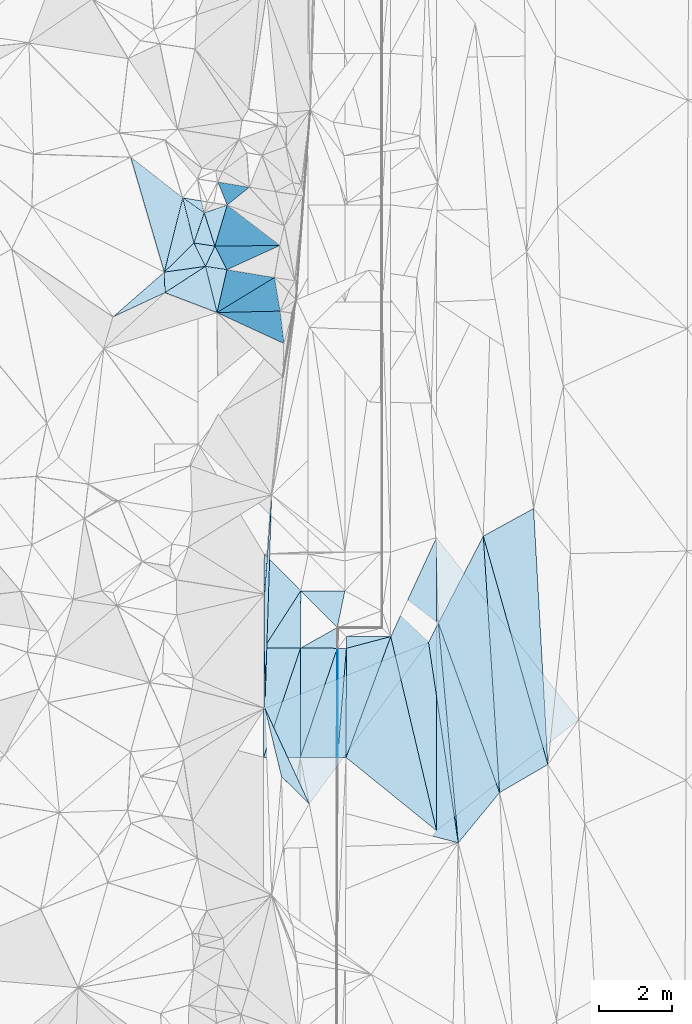
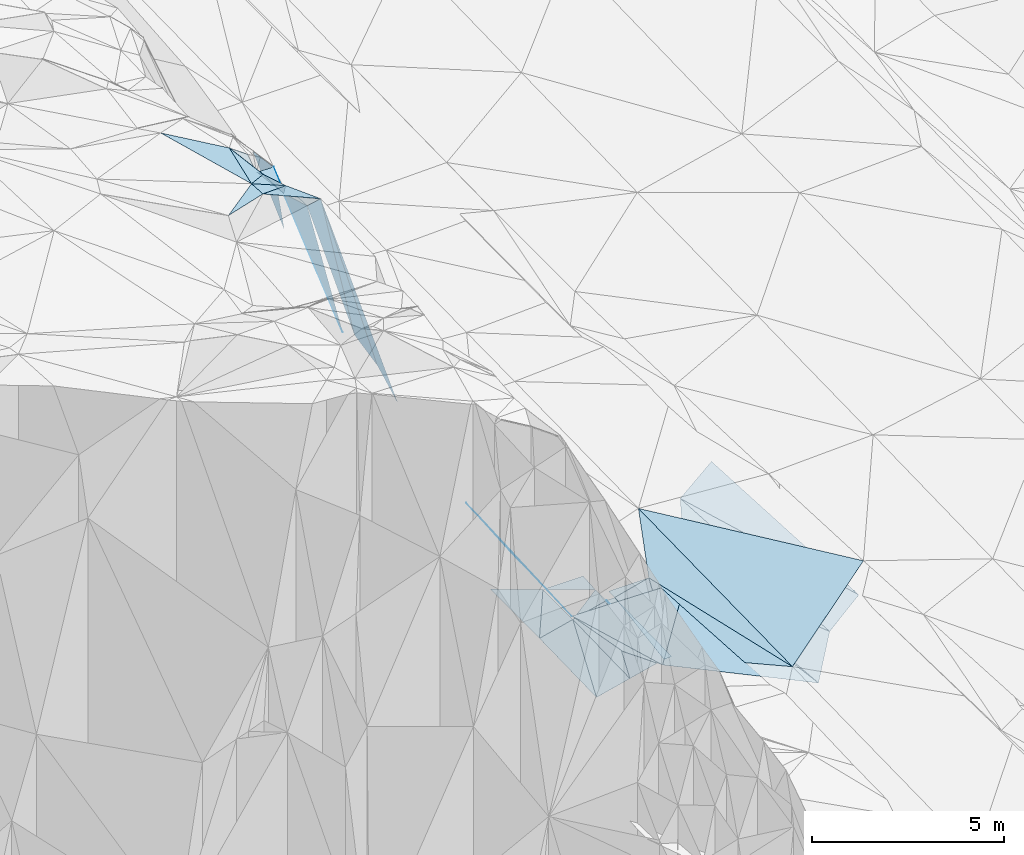
# One storey, part 128 of 275: 45 plates.
"""IFC2X3 building model written with IfcOpenShell, lengths in millimetres."""

from ifc_helpers import new_model, si_unit, frame, origin_with_axes, place, context, subcontext, project, spatial, polyline, outline, extrude, material, type_object, element, save


model = new_model("IFC2X3")

# Units and contexts
model_context = context("Model", 3, precision=1e-05, world=origin_with_axes())
body_context = subcontext(model_context, "Body", "Model", "MODEL_VIEW")
ifc_project = project(units=[si_unit("LENGTHUNIT", "METRE", prefix="MILLI"), si_unit("AREAUNIT", "SQUARE_METRE"), si_unit("VOLUMEUNIT", "CUBIC_METRE"), si_unit("MASSUNIT", "GRAM", prefix="KILO"), si_unit("TIMEUNIT", "SECOND"), si_unit("PLANEANGLEUNIT", "RADIAN"), si_unit("SOLIDANGLEUNIT", "STERADIAN"), si_unit("THERMODYNAMICTEMPERATUREUNIT", "DEGREE_CELSIUS"), si_unit("LUMINOUSINTENSITYUNIT", "LUMEN")], contexts=[model_context])

# Site, building, storey
site_placement = place(None, origin_with_axes())
site = spatial("IfcSite", under=ifc_project, at=site_placement, CompositionType="ELEMENT")
building_placement = place(site_placement, origin_with_axes())
building = spatial("IfcBuilding", under=site, at=building_placement, Name="Undefined", CompositionType="ELEMENT")
storey_placement = place(building_placement, origin_with_axes())
storey = spatial("IfcBuildingStorey", under=building, at=storey_placement, Name="Undefined", CompositionType="ELEMENT", Elevation=0.0)

# Plates
ifc_material = material()
plate_type_1 = type_object("IfcPlateType", PredefinedType="NOTDEFINED")
plate_1_placement = place(storey_placement, frame((-96862.2838496765, 102974.29921153, 42986.9687329443), z_axis=(0.049996682226141, 0.0208934366043597, -0.998530818789905), x_axis=(0.998746754522102, -0.00334002093315476, 0.0499376069884717)))
element("IfcPlate", 1, at=plate_1_placement, inside=storey, type_object=plate_type_1, material=ifc_material, Name="00_PR", context=body_context, shape_type="SweptSolid", body=[
    extrude(outline(polyline([(0.0, 0.0), (20.0249881744385, 1.60071067512035e-10), (17.6402015686035, 2980.13647460938), (0.0, 0.0)])), frame((-8.85201319254618e-08, 2.18876761149539e-07, -0.5000001331573), z_axis=(0.0, 0.0, 1.0), x_axis=(1.0, 0.0, 0.0)), (0.0, 0.0, 1.0), 1.0),
])
plate_2_placement = place(storey_placement, frame((-96851.4954782346, 99994.7710489504, 42925.1647329942), z_axis=(0.0499863724246806, 0.0208934094215203, -0.998531335519605), x_axis=(-0.998748276851681, 0.00284812192150857, -0.049937637982968)))
element("IfcPlate", 2, at=plate_2_placement, inside=storey, type_object=plate_type_1, material=ifc_material, Name="00_PR", context=body_context, shape_type="SweptSolid", body=[
    extrude(outline(polyline([(0.0, 0.0), (20.0249881744385, 1.60071067512035e-10), (16.1745891571045, 2980.14477539063), (0.0, 0.0)])), frame((-8.85201319254618e-08, 2.18876761149539e-07, -0.5000001331573), z_axis=(0.0, 0.0, 1.0), x_axis=(1.0, 0.0, 0.0)), (0.0, 0.0, 1.0), 1.0),
])
plate_type_2 = type_object("IfcPlateType", PredefinedType="NOTDEFINED")
plate_3_placement = place(storey_placement, frame((-96612.285156813, 102973.464284992, 42999.4687329028), z_axis=(0.049996682226141, 0.0208934366043597, -0.998530818789905), x_axis=(-0.0800246849124148, -0.996482893923361, -0.02485743194284)))
element("IfcPlate", 3, at=plate_3_placement, inside=storey, type_object=plate_type_2, material=ifc_material, Name="00_PR", context=body_context, shape_type="SweptSolid", body=[
    extrude(outline(polyline([(0.0, 0.0), (2989.20654296875, -5.06406649947166e-09), (17.9261016845703, 229.588638305664), (0.0, 0.0)])), frame((-8.85201319254618e-08, 2.18876761149539e-07, -0.5000001331573), z_axis=(0.0, 0.0, 1.0), x_axis=(1.0, 0.0, 0.0)), (0.0, 0.0, 1.0), 1.0),
])
plate_4_placement = place(storey_placement, frame((-96851.4954782346, 99994.7710489504, 42925.1647329942), z_axis=(0.0499863724246806, 0.0208934094215203, -0.998531335519605), x_axis=(0.0800246849207504, 0.996482893922768, 0.0248574319397589)))
element("IfcPlate", 4, at=plate_4_placement, inside=storey, type_object=plate_type_2, material=ifc_material, Name="00_PR", context=body_context, shape_type="SweptSolid", body=[
    extrude(outline(polyline([(0.0, 0.0), (2989.20654296875, -5.06406649947166e-09), (18.039421081543, 229.579437255859), (0.0, 0.0)])), frame((-8.85201319254618e-08, 2.18876761149539e-07, -0.5000001331573), z_axis=(0.0, 0.0, 1.0), x_axis=(1.0, 0.0, 0.0)), (0.0, 0.0, 1.0), 1.0),
])
plate_type_3 = type_object("IfcPlateType", PredefinedType="NOTDEFINED")
plate_5_placement = place(storey_placement, frame((-96860.382840688, 103542.363077853, 42988.3914311862), z_axis=(0.00430015277527414, -0.238494151480408, -0.971134413145652), x_axis=(-0.695041783971253, 0.697503473876836, -0.174372654002295)))
element("IfcPlate", 5, at=plate_5_placement, inside=storey, type_object=plate_type_3, material=ifc_material, Name="00_PR", context=body_context, shape_type="SweptSolid", body=[
    extrude(outline(polyline([(0.0, 0.0), (1433.71105957031, -2.65481503447518e-09), (596.104553222656, 864.556274414063), (0.0, 0.0)])), frame((-8.85201319254618e-08, 2.18876761149539e-07, -0.5000001331573), z_axis=(0.0, 0.0, 1.0), x_axis=(1.0, 0.0, 0.0)), (0.0, 0.0, 1.0), 1.0),
])
plate_type_4 = type_object("IfcPlateType", PredefinedType="NOTDEFINED")
plate_6_placement = place(storey_placement, frame((-98862.1763372869, 102980.966351325, 42486.9829273515), z_axis=(0.242537009027939, 3.20538855099889e-05, -0.970142153616845), x_axis=(0.536466447041873, 0.833191984191092, 0.134144953978825)))
element("IfcPlate", 6, at=plate_6_placement, inside=storey, type_object=plate_type_4, material=ifc_material, Name="00_PR", context=body_context, shape_type="SweptSolid", body=[
    extrude(outline(polyline([(0.0, 0.0), (1874.1591796875, 1.32422428578138e-09), (567.217834472656, 860.676391601563), (0.0, 0.0)])), frame((-8.85201319254618e-08, 2.18876761149539e-07, -0.5000001331573), z_axis=(0.0, 0.0, 1.0), x_axis=(1.0, 0.0, 0.0)), (0.0, 0.0, 1.0), 1.0),
])
plate_7_placement = place(storey_placement, frame((-97856.7525432366, 104542.50059491, 42738.3919937758), z_axis=(0.243065923693521, -0.000329820572026213, -0.970009715393308), x_axis=(-0.536466447050124, -0.833191984186519, -0.134144953974226)))
element("IfcPlate", 7, at=plate_7_placement, inside=storey, type_object=plate_type_4, material=ifc_material, Name="00_PR", context=body_context, shape_type="SweptSolid", body=[
    extrude(outline(polyline([(0.0, 0.0), (1874.1591796875, 1.32422428578138e-09), (-265.208618164063, 1408.87963867188), (0.0, 0.0)])), frame((-8.85201319254618e-08, 2.18876761149539e-07, -0.5000001331573), z_axis=(0.0, 0.0, 1.0), x_axis=(1.0, 0.0, 0.0)), (0.0, 0.0, 1.0), 1.0),
])
plate_type_5 = type_object("IfcPlateType", PredefinedType="NOTDEFINED")
plate_8_placement = place(storey_placement, frame((-96862.1875765239, 102974.289556526, 42986.9829284883), z_axis=(0.242541583059473, 0.00158451507598922, -0.970139716638268), x_axis=(-0.970137090056234, 0.00323909793626276, -0.242535636024445)))
element("IfcPlate", 8, at=plate_8_placement, inside=storey, type_object=plate_type_5, material=ifc_material, Name="00_PR", context=body_context, shape_type="SweptSolid", body=[
    extrude(outline(polyline([(0.0, 0.0), (1030.7763671875, 4.52564563602209e-09), (-0.367702662944794, 568.198425292969), (0.0, 0.0)])), frame((-8.85201319254618e-08, 2.18876761149539e-07, -0.5000001331573), z_axis=(0.0, 0.0, 1.0), x_axis=(1.0, 0.0, 0.0)), (0.0, 0.0, 1.0), 1.0),
])
plate_type_6 = type_object("IfcPlateType", PredefinedType="NOTDEFINED")
plate_9_placement = place(storey_placement, frame((-97871.3958720501, 99997.6721049398, 42674.1790293486), z_axis=(0.242551758759357, 0.0196918976460659, -0.969938592638647), x_axis=(0.00309125493136993, 0.999773210546952, 0.02107063396266)))
element("IfcPlate", 9, at=plate_9_placement, inside=storey, type_object=plate_type_6, material=ifc_material, Name="00_PR", context=body_context, shape_type="SweptSolid", body=[
    extrude(outline(polyline([(0.0, 0.0), (2980.64135742188, -1.81171344593167e-08), (2985.662109375, 1030.76416015625), (0.0, 0.0)])), frame((-8.85201319254618e-08, 2.18876761149539e-07, -0.5000001331573), z_axis=(0.0, 0.0, 1.0), x_axis=(1.0, 0.0, 0.0)), (0.0, 0.0, 1.0), 1.0),
])
plate_10_placement = place(storey_placement, frame((-98871.3913268207, 100000.516214785, 42424.1790281348), z_axis=(0.242542345699634, 0.0196919757331359, -0.969940944921001), x_axis=(0.319466040015562, 0.942410109271197, 0.099018357996012)))
element("IfcPlate", 10, at=plate_10_placement, inside=storey, type_object=plate_type_6, material=ifc_material, Name="00_PR", context=body_context, shape_type="SweptSolid", body=[
    extrude(outline(polyline([(0.0, 0.0), (3159.05053710938, -1.81462382897735e-08), (341.538848876953, 972.548278808594), (0.0, 0.0)])), frame((-8.85201319254618e-08, 2.18876761149539e-07, -0.5000001331573), z_axis=(0.0, 0.0, 1.0), x_axis=(1.0, 0.0, 0.0)), (0.0, 0.0, 1.0), 1.0),
])
plate_11_placement = place(storey_placement, frame((-97862.1819504323, 102977.637393445, 42736.9830290488), z_axis=(0.242551764417584, 0.0196885427448689, -0.969938659329806), x_axis=(-0.319466040017397, -0.942410109271267, -0.0990183579894254)))
element("IfcPlate", 11, at=plate_11_placement, inside=storey, type_object=plate_type_6, material=ifc_material, Name="00_PR", context=body_context, shape_type="SweptSolid", body=[
    extrude(outline(polyline([(0.0, 0.0), (3159.05053710938, -1.81462382897735e-08), (341.072326660156, 972.712463378906), (0.0, 0.0)])), frame((-8.85201319254618e-08, 2.18876761149539e-07, -0.5000001331573), z_axis=(0.0, 0.0, 1.0), x_axis=(1.0, 0.0, 0.0)), (0.0, 0.0, 1.0), 1.0),
])
plate_12_placement = place(storey_placement, frame((-96862.1875785642, 102974.298610799, 42986.9830277271), z_axis=(0.242542047585417, 0.0196954378779022, -0.969940949171583), x_axis=(-0.00309096492302915, -0.999773137821508, -0.021074126942329)))
element("IfcPlate", 12, at=plate_12_placement, inside=storey, type_object=plate_type_6, material=ifc_material, Name="00_PR", context=body_context, shape_type="SweptSolid", body=[
    extrude(outline(polyline([(0.0, 0.0), (2980.14721679688, 1.49739207699895e-08), (2985.66259765625, 1030.76245117188), (0.0, 0.0)])), frame((-8.85201319254618e-08, 2.18876761149539e-07, -0.5000001331573), z_axis=(0.0, 0.0, 1.0), x_axis=(1.0, 0.0, 0.0)), (0.0, 0.0, 1.0), 1.0),
])
plate_type_7 = type_object("IfcPlateType", PredefinedType="NOTDEFINED")
plate_13_placement = place(storey_placement, frame((-95402.7128464523, 103292.407908306, 43006.2141543877), z_axis=(0.021242042744292, 0.0132306099544052, -0.999686814247484), x_axis=(0.229951902921962, -0.97316916652181, -0.00799347695399914)))
element("IfcPlate", 13, at=plate_13_placement, inside=storey, type_object=plate_type_7, material=ifc_material, Name="00_PR", context=body_context, shape_type="SweptSolid", body=[
    extrude(outline(polyline([(0.0, 0.0), (5443.31298828125, 2.88709998130798e-08), (2930.09008789063, 1945.15515136719), (0.0, 0.0)])), frame((-8.85201319254618e-08, 2.18876761149539e-07, -0.5000001331573), z_axis=(0.0, 0.0, 1.0), x_axis=(1.0, 0.0, 0.0)), (0.0, 0.0, 1.0), 1.0),
])
plate_type_8 = type_object("IfcPlateType", PredefinedType="NOTDEFINED")
plate_14_placement = place(storey_placement, frame((-94153.5608253779, 105995.146992248, 43130.823841874), z_axis=(0.054157135789731, 0.020996881818966, -0.998311642522982), x_axis=(0.00032051004151243, -0.999779206628369, -0.0210103609407845)))
element("IfcPlate", 14, at=plate_14_placement, inside=storey, type_object=plate_type_8, material=ifc_material, Name="00_PR", context=body_context, shape_type="SweptSolid", body=[
    extrude(outline(polyline([(0.0, 0.0), (8001.7666015625, 3.25817381963134e-08), (2704.35620117188, 1251.83959960938), (0.0, 0.0)])), frame((-8.85201319254618e-08, 2.18876761149539e-07, -0.5000001331573), z_axis=(0.0, 0.0, 1.0), x_axis=(1.0, 0.0, 0.0)), (0.0, 0.0, 1.0), 1.0),
])
plate_type_9 = type_object("IfcPlateType", PredefinedType="NOTDEFINED")
plate_15_placement = place(storey_placement, frame((-95402.7212627632, 103292.403493352, 43006.2140076645), z_axis=(0.00441634098337481, 0.00440173445970748, -0.999980560144078), x_axis=(-0.966935393705989, -0.254964434990583, -0.00539270698044404)))
element("IfcPlate", 15, at=plate_15_placement, inside=storey, type_object=plate_type_9, material=ifc_material, Name="00_PR", context=body_context, shape_type="SweptSolid", body=[
    extrude(outline(polyline([(0.0, 0.0), (1250.94885253906, -3.63797880709171e-10), (1168.564453125, 308.201049804688), (0.0, 0.0)])), frame((-8.85201319254618e-08, 2.18876761149539e-07, -0.5000001331573), z_axis=(0.0, 0.0, 1.0), x_axis=(1.0, 0.0, 0.0)), (0.0, 0.0, 1.0), 1.0),
])
plate_type_10 = type_object("IfcPlateType", PredefinedType="NOTDEFINED")
plate_16_placement = place(storey_placement, frame((-96621.5216342353, 99994.1168148522, 42936.6641093038), z_axis=(1.87418797431457e-05, 0.0210750427160419, -0.999777896446635), x_axis=(0.00309107992673195, 0.999773119063399, 0.0210749999556371)))
element("IfcPlate", 16, at=plate_16_placement, inside=storey, type_object=plate_type_10, material=ifc_material, Name="00_PR", context=body_context, shape_type="SweptSolid", body=[
    extrude(outline(polyline([(0.0, 0.0), (2980.02368164063, -1.57306203618646e-08), (3302.77978515625, 1208.59484863281), (0.0, 0.0)])), frame((-8.85201319254618e-08, 2.18876761149539e-07, -0.5000001331573), z_axis=(0.0, 0.0, 1.0), x_axis=(1.0, 0.0, 0.0)), (0.0, 0.0, 1.0), 1.0),
])
plate_type_11 = type_object("IfcPlateType", PredefinedType="NOTDEFINED")
plate_17_placement = place(storey_placement, frame((-94151.0098670523, 97995.1472996871, 42962.7032885683), z_axis=(0.0267956999450868, 0.0210114042527837, -0.999420087528652), x_axis=(-0.000320510089253997, 0.999779206628115, 0.0210103609521533)))
element("IfcPlate", 17, at=plate_17_placement, inside=storey, type_object=plate_type_11, material=ifc_material, Name="00_PR", context=body_context, shape_type="SweptSolid", body=[
    extrude(outline(polyline([(0.0, 0.0), (8001.7666015625, 3.25817381963134e-08), (3026.46215820313, 3877.703125), (0.0, 0.0)])), frame((-8.85201319254618e-08, 2.18876761149539e-07, -0.5000001331573), z_axis=(0.0, 0.0, 1.0), x_axis=(1.0, 0.0, 0.0)), (0.0, 0.0, 1.0), 1.0),
])
plate_type_12 = type_object("IfcPlateType", PredefinedType="NOTDEFINED")
plate_18_placement = place(storey_placement, frame((-101580.615464358, 113236.098327771, 51639.5047972381), z_axis=(-0.136729364052396, -0.0221065300963484, -0.990361743169094), x_axis=(0.0324325562643588, -0.999314897978789, 0.0178287400508597)))
element("IfcPlate", 18, at=plate_18_placement, inside=storey, type_object=plate_type_12, material=ifc_material, Name="00", context=body_context, shape_type="SweptSolid", body=[
    extrude(outline(polyline([(0.0, 0.0), (560.892150878906, 3.50701157003641e-09), (1176.5185546875, 1449.00109863281), (0.0, 0.0)])), frame((-8.85201319254618e-08, 2.18876761149539e-07, -0.5000001331573), z_axis=(0.0, 0.0, 1.0), x_axis=(1.0, 0.0, 0.0)), (0.0, 0.0, 1.0), 1.0),
])
plate_type_13 = type_object("IfcPlateType", PredefinedType="NOTDEFINED")
plate_19_placement = place(storey_placement, frame((-100492.362316181, 114854.413875621, 50639.7044283382), z_axis=(-0.799366211893587, -0.107767225606642, -0.591100570434461), x_axis=(0.297864111387015, -0.925462604204437, -0.234085324970973)))
element("IfcPlate", 19, at=plate_19_placement, inside=storey, type_object=plate_type_13, material=ifc_material, Name="00", context=body_context, shape_type="SweptSolid", body=[
    extrude(outline(polyline([(0.0, 0.0), (982.547729492188, -8.23638401925564e-09), (554.7822265625, 854.878173828125), (0.0, 0.0)])), frame((-8.85201319254618e-08, 2.18876761149539e-07, -0.5000001331573), z_axis=(0.0, 0.0, 1.0), x_axis=(1.0, 0.0, 0.0)), (0.0, 0.0, 1.0), 1.0),
])
plate_type_14 = type_object("IfcPlateType", PredefinedType="NOTDEFINED")
plate_20_placement = place(storey_placement, frame((-100121.182069803, 115696.336922559, 50669.8614109049), z_axis=(-0.918566734797253, -0.281836467074313, -0.277134190512436), x_axis=(0.302649221087705, -0.0505173689415557, -0.951762283561514)))
element("IfcPlate", 20, at=plate_20_placement, inside=storey, type_object=plate_type_14, material=ifc_material, Name="00", context=body_context, shape_type="SweptSolid", body=[
    extrude(outline(polyline([(0.0, 0.0), (2847.349609375, -6.92671164870262e-09), (309.375427246094, 641.238525390625), (0.0, 0.0)])), frame((-8.85201319254618e-08, 2.18876761149539e-07, -0.5000001331573), z_axis=(0.0, 0.0, 1.0), x_axis=(1.0, 0.0, 0.0)), (0.0, 0.0, 1.0), 1.0),
])
plate_type_15 = type_object("IfcPlateType", PredefinedType="NOTDEFINED")
plate_21_placement = place(storey_placement, frame((-91115.9612460273, 99802.2205734174, 43081.5065323016), z_axis=(0.15874901185345, 0.0282371687799725, -0.986915099456303), x_axis=(-0.854186650664828, -0.497366704420545, -0.151629572181185)))
element("IfcPlate", 21, at=plate_21_placement, inside=storey, type_object=plate_type_15, material=ifc_material, Name="00", context=body_context, shape_type="SweptSolid", body=[
    extrude(outline(polyline([(0.0, 0.0), (1543.23461914063, -8.92032403498888e-09), (-1579.216796875, 6281.49072265625), (0.0, 0.0)])), frame((-8.85201319254618e-08, 2.18876761149539e-07, -0.5000001331573), z_axis=(0.0, 0.0, 1.0), x_axis=(1.0, 0.0, 0.0)), (0.0, 0.0, 1.0), 1.0),
])
plate_type_16 = type_object("IfcPlateType", PredefinedType="NOTDEFINED")
plate_22_placement = place(storey_placement, frame((-101562.574163744, 112675.586399513, 51649.5503692574), z_axis=(-0.436456330775217, -0.0302080173835198, -0.899218186544284), x_axis=(-0.0324325562880686, 0.999314897978066, -0.0178287400482765)))
element("IfcPlate", 22, at=plate_22_placement, inside=storey, type_object=plate_type_16, material=ifc_material, Name="00", context=body_context, shape_type="SweptSolid", body=[
    extrude(outline(polyline([(0.0, 0.0), (560.892150878906, 3.50701157003641e-09), (691.398498535156, 1252.86401367188), (0.0, 0.0)])), frame((-8.85201319254618e-08, 2.18876761149539e-07, -0.5000001331573), z_axis=(0.0, 0.0, 1.0), x_axis=(1.0, 0.0, 0.0)), (0.0, 0.0, 1.0), 1.0),
])
plate_type_17 = type_object("IfcPlateType", PredefinedType="NOTDEFINED")
plate_23_placement = place(storey_placement, frame((-98651.393709004, 107158.689872287, 44186.6732256583), z_axis=(-0.756522406755127, 0.0245735633164275, -0.653505920450124), x_axis=(-0.0318725917190349, -0.99949170400834, -0.000686669947191996)))
element("IfcPlate", 23, at=plate_23_placement, inside=storey, type_object=plate_type_17, material=ifc_material, Name="00", context=body_context, shape_type="SweptSolid", body=[
    extrude(outline(polyline([(0.0, 0.0), (5825.2119140625, -2.13622115552425e-08), (2711.36694335938, 164.960144042969), (0.0, 0.0)])), frame((-8.85201319254618e-08, 2.18876761149539e-07, -0.5000001331573), z_axis=(0.0, 0.0, 1.0), x_axis=(1.0, 0.0, 0.0)), (0.0, 0.0, 1.0), 1.0),
])
plate_type_18 = type_object("IfcPlateType", PredefinedType="NOTDEFINED")
plate_24_placement = place(storey_placement, frame((-101077.273030823, 115262.777438878, 51369.5706306581), z_axis=(-0.512323091033733, 0.0128892904712874, -0.858696055996991), x_axis=(0.236767208225277, -0.959016204619489, -0.155657342860653)))
element("IfcPlate", 24, at=plate_24_placement, inside=storey, type_object=plate_type_18, material=ifc_material, Name="00", context=body_context, shape_type="SweptSolid", body=[
    extrude(outline(polyline([(0.0, 0.0), (1284.87353515625, 5.16592990607023e-09), (1782.35437011719, 1121.16577148438), (0.0, 0.0)])), frame((-8.85201319254618e-08, 2.18876761149539e-07, -0.5000001331573), z_axis=(0.0, 0.0, 1.0), x_axis=(1.0, 0.0, 0.0)), (0.0, 0.0, 1.0), 1.0),
])
plate_type_19 = type_object("IfcPlateType", PredefinedType="NOTDEFINED")
plate_25_placement = place(storey_placement, frame((-92434.1387540705, 99034.6690419979, 42847.5130140628), z_axis=(0.224515676653957, 0.0321609744613174, -0.973939619616285), x_axis=(-0.339002715695668, 0.939604591257534, -0.0471208111000276)))
element("IfcPlate", 25, at=plate_25_placement, inside=storey, type_object=plate_type_19, material=ifc_material, Name="00", context=body_context, shape_type="SweptSolid", body=[
    extrude(outline(polyline([(0.0, 0.0), (4923.5146484375, 2.13913153856993e-08), (6720.9423828125, 2008.92016601563), (0.0, 0.0)])), frame((-8.85201319254618e-08, 2.18876761149539e-07, -0.5000001331573), z_axis=(0.0, 0.0, 1.0), x_axis=(1.0, 0.0, 0.0)), (0.0, 0.0, 1.0), 1.0),
])
plate_type_20 = type_object("IfcPlateType", PredefinedType="NOTDEFINED")
plate_26_placement = place(storey_placement, frame((-93560.5857388033, 97665.2577040772, 42438.5210852868), z_axis=(0.28232433321874, 0.0538269394079939, -0.957807721553007), x_axis=(-0.0900942054923928, 0.995499536525098, 0.0293888910136048)))
element("IfcPlate", 26, at=plate_26_placement, inside=storey, type_object=plate_type_20, material=ifc_material, Name="00", context=body_context, shape_type="SweptSolid", body=[
    extrude(outline(polyline([(0.0, 0.0), (6022.68408203125, -2.57568899542093e-09), (1273.79028320313, 1299.61706542969), (0.0, 0.0)])), frame((-8.85201319254618e-08, 2.18876761149539e-07, -0.5000001331573), z_axis=(0.0, 0.0, 1.0), x_axis=(1.0, 0.0, 0.0)), (0.0, 0.0, 1.0), 1.0),
])
plate_type_21 = type_object("IfcPlateType", PredefinedType="NOTDEFINED")
plate_27_placement = place(storey_placement, frame((-99871.9757250991, 113302.660641522, 50299.7274697086), z_axis=(-0.780945191015204, -0.305090547394151, -0.545017767160819), x_axis=(-0.593711109448391, 0.0915850148937867, 0.799449375235522)))
element("IfcPlate", 27, at=plate_27_placement, inside=storey, type_object=plate_type_21, material=ifc_material, Name="00", context=body_context, shape_type="SweptSolid", body=[
    extrude(outline(polyline([(0.0, 0.0), (988.18017578125, -2.4156179279089e-09), (341.334533691406, 644.663269042969), (0.0, 0.0)])), frame((-8.85201319254618e-08, 2.18876761149539e-07, -0.5000001331573), z_axis=(0.0, 0.0, 1.0), x_axis=(1.0, 0.0, 0.0)), (0.0, 0.0, 1.0), 1.0),
])
plate_28_placement = place(storey_placement, frame((-100458.666094716, 113393.158995344, 51089.7253153897), z_axis=(-0.774623479278632, -0.313366842716643, -0.549326576123958), x_axis=(-0.439815872221123, 0.891093335750631, 0.111868965862683)))
element("IfcPlate", 28, at=plate_28_placement, inside=storey, type_object=plate_type_21, material=ifc_material, Name="00", context=body_context, shape_type="SweptSolid", body=[
    extrude(outline(polyline([(0.0, 0.0), (715.122375488281, -4.05270839110017e-09), (301.766540527344, 861.937927246094), (0.0, 0.0)])), frame((-8.85201319254618e-08, 2.18876761149539e-07, -0.5000001331573), z_axis=(0.0, 0.0, 1.0), x_axis=(1.0, 0.0, 0.0)), (0.0, 0.0, 1.0), 1.0),
])
plate_type_22 = type_object("IfcPlateType", PredefinedType="NOTDEFINED")
plate_29_placement = place(storey_placement, frame((-99864.5134965314, 115066.600383419, 50459.8410389227), z_axis=(-0.904418503613813, 0.284568713235642, -0.31788019404858), x_axis=(0.26672402524393, -0.204397318966636, -0.941849260952583)))
element("IfcPlate", 29, at=plate_29_placement, inside=storey, type_object=plate_type_22, material=ifc_material, Name="00", context=body_context, shape_type="SweptSolid", body=[
    extrude(outline(polyline([(0.0, 0.0), (5393.64453125, -1.90775608643889e-08), (186.868087768555, 1156.40832519531), (0.0, 0.0)])), frame((-8.85201319254618e-08, 2.18876761149539e-07, -0.5000001331573), z_axis=(0.0, 0.0, 1.0), x_axis=(1.0, 0.0, 0.0)), (0.0, 0.0, 1.0), 1.0),
])
plate_type_23 = type_object("IfcPlateType", PredefinedType="NOTDEFINED")
plate_30_placement = place(storey_placement, frame((-100142.410028978, 112133.71564454, 51329.8612798614), z_axis=(-0.954951938695623, 0.105438761441521, -0.277397661070077), x_axis=(0.279596356333159, 0.00637880803596602, -0.960096447412062)))
element("IfcPlate", 30, at=plate_30_placement, inside=storey, type_object=plate_type_23, material=ifc_material, Name="00", context=body_context, shape_type="SweptSolid", body=[
    extrude(outline(polyline([(0.0, 0.0), (6155.63134765625, -7.43602868169546e-09), (6851.67724609375, 891.975646972656), (0.0, 0.0)])), frame((-8.85201319254618e-08, 2.18876761149539e-07, -0.5000001331573), z_axis=(0.0, 0.0, 1.0), x_axis=(1.0, 0.0, 0.0)), (0.0, 0.0, 1.0), 1.0),
])
plate_type_24 = type_object("IfcPlateType", PredefinedType="NOTDEFINED")
plate_31_placement = place(storey_placement, frame((-100773.202712074, 114030.504840019, 51169.706854288), z_axis=(-0.803528892522284, -0.10322622913036, -0.58624710191304), x_axis=(-0.236767208229272, 0.959016204620543, 0.155657342848081)))
element("IfcPlate", 31, at=plate_31_placement, inside=storey, type_object=plate_type_24, material=ifc_material, Name="00", context=body_context, shape_type="SweptSolid", body=[
    extrude(outline(polyline([(0.0, 0.0), (1284.87353515625, 5.16592990607023e-09), (641.152587890625, 792.163696289063), (0.0, 0.0)])), frame((-8.85201319254618e-08, 2.18876761149539e-07, -0.5000001331573), z_axis=(0.0, 0.0, 1.0), x_axis=(1.0, 0.0, 0.0)), (0.0, 0.0, 1.0), 1.0),
])
plate_type_25 = type_object("IfcPlateType", PredefinedType="NOTDEFINED")
plate_32_placement = place(storey_placement, frame((-94103.4430941372, 103660.814592372, 42615.5116468142), z_axis=(-0.21452745058472, 0.00941802841001878, -0.976672551926432), x_axis=(0.0900942055178325, -0.995499536524162, -0.0293888909673215)))
element("IfcPlate", 32, at=plate_32_placement, inside=storey, type_object=plate_type_25, material=ifc_material, Name="00", context=body_context, shape_type="SweptSolid", body=[
    extrude(outline(polyline([(0.0, 0.0), (6022.68408203125, -2.57568899542093e-09), (494.122711181641, 322.131561279297), (0.0, 0.0)])), frame((-8.85201319254618e-08, 2.18876761149539e-07, -0.5000001331573), z_axis=(0.0, 0.0, 1.0), x_axis=(1.0, 0.0, 0.0)), (0.0, 0.0, 1.0), 1.0),
])
plate_type_26 = type_object("IfcPlateType", PredefinedType="NOTDEFINED")
plate_33_placement = place(storey_placement, frame((-100773.014388936, 114030.507537946, 51169.5504777802), z_axis=(-0.426877672289988, -0.0978316855632786, -0.899001898885719), x_axis=(0.439815872212659, -0.891093335755049, -0.111868965860765)))
element("IfcPlate", 33, at=plate_33_placement, inside=storey, type_object=plate_type_26, material=ifc_material, Name="00", context=body_context, shape_type="SweptSolid", body=[
    extrude(outline(polyline([(0.0, 0.0), (715.122375488281, -4.05270839110017e-09), (300.088500976563, 1189.30517578125), (0.0, 0.0)])), frame((-8.85201319254618e-08, 2.18876761149539e-07, -0.5000001331573), z_axis=(0.0, 0.0, 1.0), x_axis=(1.0, 0.0, 0.0)), (0.0, 0.0, 1.0), 1.0),
])
plate_type_27 = type_object("IfcPlateType", PredefinedType="NOTDEFINED")
plate_34_placement = place(storey_placement, frame((-100142.412330052, 112133.650354501, 51329.8597800274), z_axis=(-0.959554697836772, -0.0251431471604483, -0.280397225396845), x_axis=(0.170951878934271, 0.739302488997438, -0.651311971985035)))
element("IfcPlate", 34, at=plate_34_placement, inside=storey, type_object=plate_type_27, material=ifc_material, Name="00", context=body_context, shape_type="SweptSolid", body=[
    extrude(outline(polyline([(0.0, 0.0), (1581.42346191406, -7.97444954514503e-09), (4523.96240234375, 3550.5302734375), (0.0, 0.0)])), frame((-8.85201319254618e-08, 2.18876761149539e-07, -0.5000001331573), z_axis=(0.0, 0.0, 1.0), x_axis=(1.0, 0.0, 0.0)), (0.0, 0.0, 1.0), 1.0),
])
plate_type_28 = type_object("IfcPlateType", PredefinedType="NOTDEFINED")
plate_35_placement = place(storey_placement, frame((-102497.466671124, 116373.271706081, 51669.5175803614), z_axis=(-0.254787051007588, -0.0652311836818512, -0.964794512481451), x_axis=(0.777096045293997, -0.607602228850885, -0.164137953818935)))
element("IfcPlate", 35, at=plate_35_placement, inside=storey, type_object=plate_type_28, material=ifc_material, Name="00", context=body_context, shape_type="SweptSolid", body=[
    extrude(outline(polyline([(0.0, 0.0), (1827.73083496094, 7.90896592661738e-09), (2623.5263671875, 1949.48950195313), (0.0, 0.0)])), frame((-8.85201319254618e-08, 2.18876761149539e-07, -0.5000001331573), z_axis=(0.0, 0.0, 1.0), x_axis=(1.0, 0.0, 0.0)), (0.0, 0.0, 1.0), 1.0),
])
plate_type_29 = type_object("IfcPlateType", PredefinedType="NOTDEFINED")
plate_36_placement = place(storey_placement, frame((-100199.454522003, 113945.224652659, 50409.530371192), z_axis=(-0.315198620975236, 0.136115484496008, -0.939213715943143), x_axis=(-0.2978641113905, 0.92546260420627, 0.23408532495929)))
element("IfcPlate", 36, at=plate_36_placement, inside=storey, type_object=plate_type_29, material=ifc_material, Name="00", context=body_context, shape_type="SweptSolid", body=[
    extrude(outline(polyline([(0.0, 0.0), (982.547729492188, -8.23638401925564e-09), (949.572204589844, 685.939208984375), (0.0, 0.0)])), frame((-8.85201319254618e-08, 2.18876761149539e-07, -0.5000001331573), z_axis=(0.0, 0.0, 1.0), x_axis=(1.0, 0.0, 0.0)), (0.0, 0.0, 1.0), 1.0),
])
plate_type_30 = type_object("IfcPlateType", PredefinedType="NOTDEFINED")
plate_37_placement = place(storey_placement, frame((-92877.2361040219, 106034.229554957, 42976.5062549237), z_axis=(0.155508696973327, 0.0273122708248737, -0.987456877553672), x_axis=(0.866773573628456, 0.475715443434261, 0.149660913192125)))
element("IfcPlate", 37, at=plate_37_placement, inside=storey, type_object=plate_type_30, material=ifc_material, Name="00", context=body_context, shape_type="SweptSolid", body=[
    extrude(outline(polyline([(0.0, 0.0), (1583.57983398438, -7.07223080098629e-09), (-1422.32360839844, 6318.8642578125), (0.0, 0.0)])), frame((-8.85201319254618e-08, 2.18876761149539e-07, -0.5000001331573), z_axis=(0.0, 0.0, 1.0), x_axis=(1.0, 0.0, 0.0)), (0.0, 0.0, 1.0), 1.0),
])
plate_type_31 = type_object("IfcPlateType", PredefinedType="NOTDEFINED")
plate_38_placement = place(storey_placement, frame((-97625.9723102954, 98726.1308979054, 43789.5224982546), z_axis=(-0.296686206029409, 0.00614990870337784, -0.954955220821801), x_axis=(-0.69399629029016, 0.685534573346265, 0.220026129835641)))
element("IfcPlate", 38, at=plate_38_placement, inside=storey, type_object=plate_type_31, material=ifc_material, Name="00", context=body_context, shape_type="SweptSolid", body=[
    extrude(outline(polyline([(0.0, 0.0), (1090.77954101563, -5.21140464115888e-09), (2716.25, 1027.74877929688), (0.0, 0.0)])), frame((-8.85201319254618e-08, 2.18876761149539e-07, -0.5000001331573), z_axis=(0.0, 0.0, 1.0), x_axis=(1.0, 0.0, 0.0)), (0.0, 0.0, 1.0), 1.0),
])
plate_type_32 = type_object("IfcPlateType", PredefinedType="NOTDEFINED")
plate_39_placement = place(storey_placement, frame((-100142.084032126, 112133.537307168, 51329.5403325579), z_axis=(-0.30295728171833, -0.251235470037865, -0.91929191449109), x_axis=(-0.914273573324386, 0.348825657840047, 0.205972069837436)))
element("IfcPlate", 39, at=plate_39_placement, inside=storey, type_object=plate_type_32, material=ifc_material, Name="00", context=body_context, shape_type="SweptSolid", body=[
    extrude(outline(polyline([(0.0, 0.0), (1553.60864257813, -1.22236087918282e-09), (679.19287109375, 1132.73876953125), (0.0, 0.0)])), frame((-8.85201319254618e-08, 2.18876761149539e-07, -0.5000001331573), z_axis=(0.0, 0.0, 1.0), x_axis=(1.0, 0.0, 0.0)), (0.0, 0.0, 1.0), 1.0),
])
plate_type_33 = type_object("IfcPlateType", PredefinedType="NOTDEFINED")
plate_40_placement = place(storey_placement, frame((-100458.669726777, 113393.165459823, 51089.726853452), z_axis=(-0.781887248240585, -0.300437703515936, -0.546250416333788), x_axis=(0.593711109445559, -0.0915850149011514, -0.799449375236781)))
element("IfcPlate", 40, at=plate_40_placement, inside=storey, type_object=plate_type_33, material=ifc_material, Name="00", context=body_context, shape_type="SweptSolid", body=[
    extrude(outline(polyline([(0.0, 0.0), (988.18017578125, -2.4156179279089e-09), (111.315734863281, 1316.05810546875), (0.0, 0.0)])), frame((-8.85201319254618e-08, 2.18876761149539e-07, -0.5000001331573), z_axis=(0.0, 0.0, 1.0), x_axis=(1.0, 0.0, 0.0)), (0.0, 0.0, 1.0), 1.0),
])
plate_type_34 = type_object("IfcPlateType", PredefinedType="NOTDEFINED")
plate_41_placement = place(storey_placement, frame((-100199.730873266, 113944.961536457, 50409.8462151806), z_axis=(-0.867890818572226, -0.39011829252245, -0.307527632705419), x_axis=(0.332577294249905, 0.00353511305373575, -0.943069375139024)))
element("IfcPlate", 41, at=plate_41_placement, inside=storey, type_object=plate_type_34, material=ifc_material, Name="00", context=body_context, shape_type="SweptSolid", body=[
    extrude(outline(polyline([(0.0, 0.0), (5333.64794921875, -2.50001903623343e-08), (210.456329345703, 698.4326171875), (0.0, 0.0)])), frame((-8.85201319254618e-08, 2.18876761149539e-07, -0.5000001331573), z_axis=(0.0, 0.0, 1.0), x_axis=(1.0, 0.0, 0.0)), (0.0, 0.0, 1.0), 1.0),
])
plate_type_35 = type_object("IfcPlateType", PredefinedType="NOTDEFINED")
plate_42_placement = place(storey_placement, frame((-98574.8699266979, 113089.063755674, 45879.8601447887), z_axis=(-0.959878572700165, -0.0204566897009528, -0.279668821139526), x_axis=(0.148130828314242, -0.883814716826189, -0.443766609857456)))
element("IfcPlate", 42, at=plate_42_placement, inside=storey, type_object=plate_type_35, material=ifc_material, Name="00", context=body_context, shape_type="SweptSolid", body=[
    extrude(outline(polyline([(0.0, 0.0), (1036.58093261719, -5.1804818212986e-09), (-1806.32299804688, 5459.82568359375), (0.0, 0.0)])), frame((-8.85201319254618e-08, 2.18876761149539e-07, -0.5000001331573), z_axis=(0.0, 0.0, 1.0), x_axis=(1.0, 0.0, 0.0)), (0.0, 0.0, 1.0), 1.0),
])
plate_type_36 = type_object("IfcPlateType", PredefinedType="NOTDEFINED")
plate_43_placement = place(storey_placement, frame((-101077.166929068, 115263.125814625, 51369.681256176), z_axis=(-0.300116245397712, 0.709644279758853, -0.637444299883463), x_axis=(0.830211868917086, -0.134772478743938, -0.540910927678868)))
element("IfcPlate", 43, at=plate_43_placement, inside=storey, type_object=plate_type_36, material=ifc_material, Name="00", context=body_context, shape_type="SweptSolid", body=[
    extrude(outline(polyline([(0.0, 0.0), (610.081970214844, 3.15048964694142e-09), (935.611999511719, 408.081115722656), (0.0, 0.0)])), frame((-8.85201319254618e-08, 2.18876761149539e-07, -0.5000001331573), z_axis=(0.0, 0.0, 1.0), x_axis=(1.0, 0.0, 0.0)), (0.0, 0.0, 1.0), 1.0),
])
plate_type_37 = type_object("IfcPlateType", PredefinedType="NOTDEFINED")
plate_44_placement = place(storey_placement, frame((-98836.8395842865, 101336.424100226, 44182.5261115353), z_axis=(-0.319034546748084, -0.00530503523456667, -0.94772823878072), x_axis=(0.884652000782741, 0.357086557582303, -0.299799979828408)))
element("IfcPlate", 44, at=plate_44_placement, inside=storey, type_object=plate_type_37, material=ifc_material, Name="00", context=body_context, shape_type="SweptSolid", body=[
    extrude(outline(polyline([(0.0, 0.0), (5046.6982421875, -6.22821971774101e-09), (256.904998779297, 2892.79833984375), (0.0, 0.0)])), frame((-8.85201319254618e-08, 2.18876761149539e-07, -0.5000001331573), z_axis=(0.0, 0.0, 1.0), x_axis=(1.0, 0.0, 0.0)), (0.0, 0.0, 1.0), 1.0),
])
plate_type_38 = type_object("IfcPlateType", PredefinedType="NOTDEFINED")
plate_45_placement = place(storey_placement, frame((-94372.2669728431, 103138.531329934, 42669.525778054), z_axis=(-0.317009863987601, -0.00696770147194113, -0.948396645539597), x_axis=(0.146513305650743, -0.98832886090514, -0.0417122760016904)))
element("IfcPlate", 45, at=plate_45_placement, inside=storey, type_object=plate_type_38, material=ifc_material, Name="00", context=body_context, shape_type="SweptSolid", body=[
    extrude(outline(polyline([(0.0, 0.0), (5537.93798828125, 1.91503204405308e-08), (3837.47875976563, 4072.36499023438), (0.0, 0.0)])), frame((-8.85201319254618e-08, 2.18876761149539e-07, -0.5000001331573), z_axis=(0.0, 0.0, 1.0), x_axis=(1.0, 0.0, 0.0)), (0.0, 0.0, 1.0), 1.0),
])

save(model, "model.ifc")
